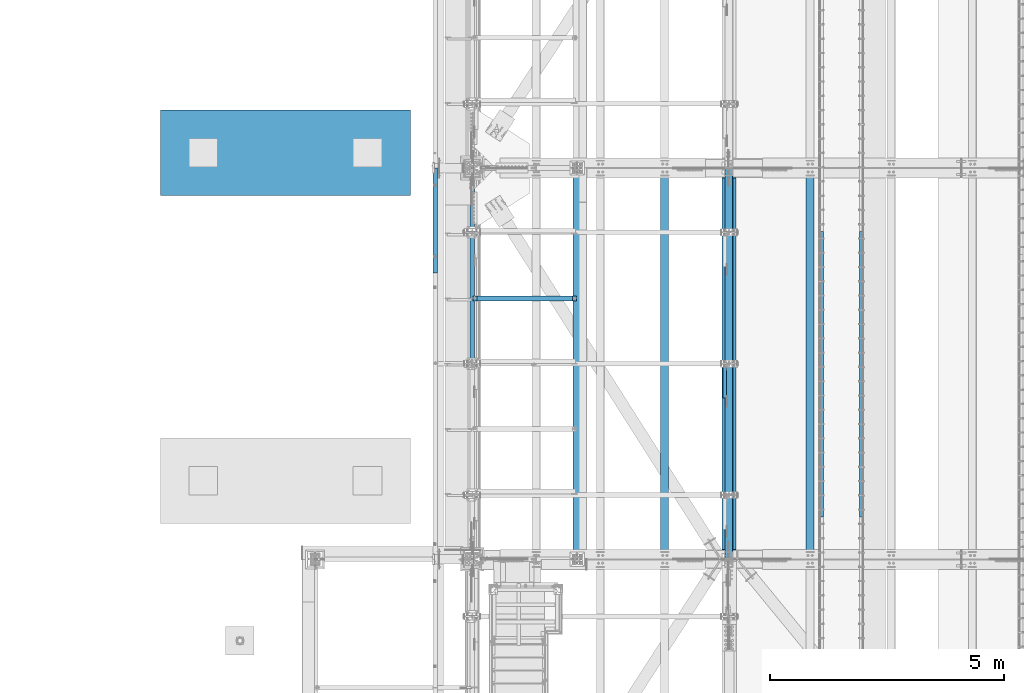
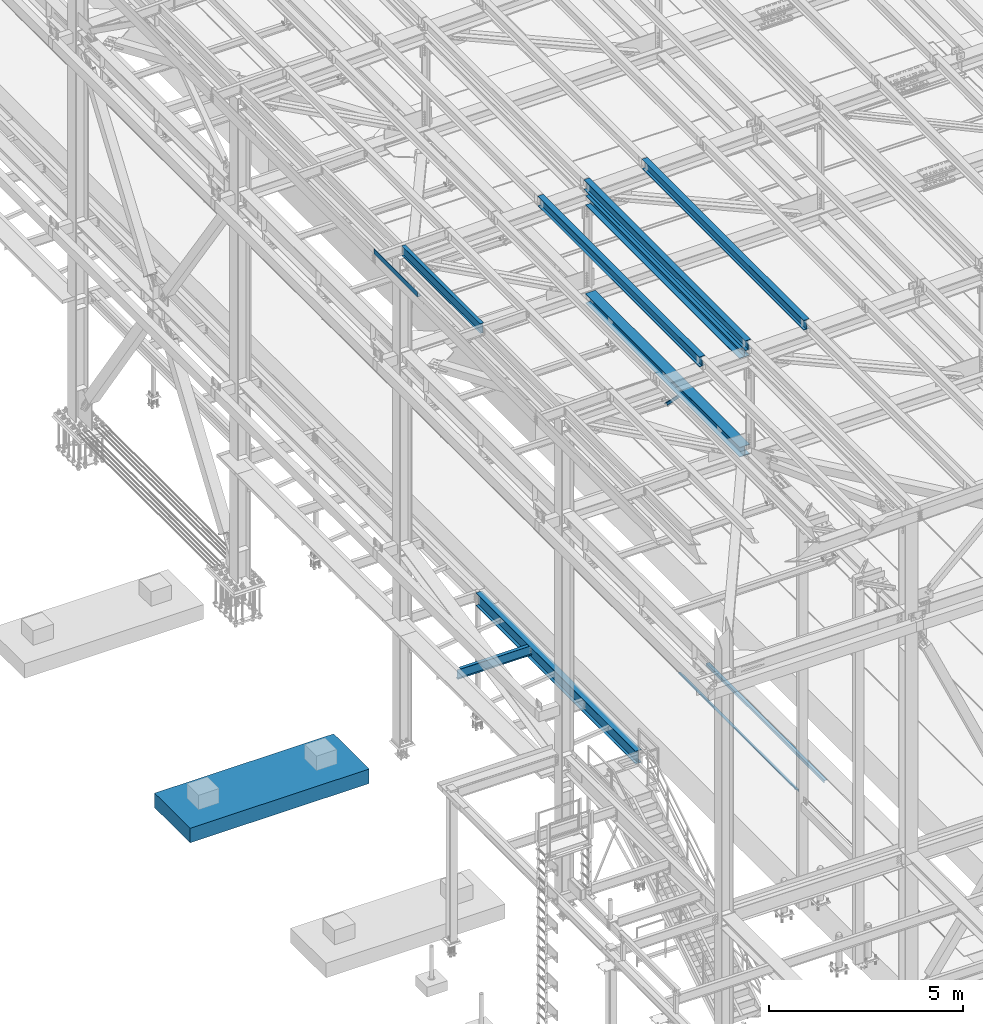
# One storey, part 1807 of 3843: 12 beams, 1 member, 13 elements without a shape of their own.
"""IFC2X3 building model written with IfcOpenShell, lengths in millimetres."""

from ifc_helpers import new_model, si_unit, frame, origin_with_axes, place, context, subcontext, project, spatial, faceted_brep, material, type_object, element, aggregate, save


model = new_model("IFC2X3")

# Units and contexts
model_context = context("Model", 3, precision=1e-05, world=origin_with_axes())
body_context = subcontext(model_context, "Body", "Model", "MODEL_VIEW")
ifc_project = project(units=[si_unit("LENGTHUNIT", "METRE", prefix="MILLI"), si_unit("AREAUNIT", "SQUARE_METRE"), si_unit("VOLUMEUNIT", "CUBIC_METRE"), si_unit("MASSUNIT", "GRAM", prefix="KILO"), si_unit("TIMEUNIT", "SECOND"), si_unit("PLANEANGLEUNIT", "RADIAN"), si_unit("SOLIDANGLEUNIT", "STERADIAN"), si_unit("THERMODYNAMICTEMPERATUREUNIT", "DEGREE_CELSIUS"), si_unit("LUMINOUSINTENSITYUNIT", "LUMEN")], contexts=[model_context])

# Site, building, storey
site_placement = place(None, origin_with_axes())
site = spatial("IfcSite", under=ifc_project, at=site_placement, CompositionType="ELEMENT")
building_placement = place(site_placement, origin_with_axes())
building = spatial("IfcBuilding", under=site, at=building_placement, Name="Undefined", CompositionType="ELEMENT")
storey_placement = place(building_placement, origin_with_axes())
storey = spatial("IfcBuildingStorey", under=building, at=storey_placement, Name="Undefined", CompositionType="ELEMENT", Elevation=0.0)

# Assembly, beam
assembly_1_placement = place(storey_placement, origin_with_axes())
assembly_1 = element("IfcElementAssembly", 1, at=assembly_1_placement, inside=storey, Name="EMBED_ANGLE", AssemblyPlace="NOTDEFINED", PredefinedType="RIGID_FRAME")
ifc_material_1 = material(Name="STEEL/A36")
beam_type_1 = type_object("IfcBeamType", Name="L3-1/2X3-1/2X5/16", PredefinedType="NOTDEFINED")
beam_1_placement = place(assembly_1_placement, frame((44887.896, 40846.375, 30419.675), z_axis=(0.0, 0.0, -1.0), x_axis=(0.0, -1.0, 0.0)))
beam_1 = element("IfcBeam", 2, at=beam_1_placement, type_object=beam_type_1, material=ifc_material_1, Name="EMBED_ANGLE", ObjectType="L3-1/2X3-1/2X5/16", context=body_context, shape_type="Brep", body=[
    faceted_brep([(-3.63797880709171e-12, 44.4499999999971, -44.4500000000007), (-3.63797880709171e-12, 44.4499999999971, 44.4500000000007), (6096.0, 44.4499999999971, 44.4500000000007), (6096.0, 44.4499999999971, -44.4500000000007), (-3.63797880709171e-12, 36.5124999999971, 44.4500000000007), (6096.0, 36.5124999999971, 44.4500000000007), (-3.63797880709171e-12, 36.5124999999971, -36.5125000000007), (6096.0, 36.5124999999971, -36.5125000000007), (3.63797880709171e-12, -44.4499999999971, -36.5125000000007), (6096.0, -44.4499999999971, -36.5125000000007), (3.63797880709171e-12, -44.4499999999971, -44.4500000000007), (6096.0, -44.4499999999971, -44.4500000000007)], [[[0, 1, 2, 3]], [[1, 4, 5, 2]], [[4, 6, 7, 5]], [[6, 8, 9, 7]], [[8, 10, 11, 9]], [[10, 0, 3, 11]], [[5, 7, 9, 11, 3, 2]], [[10, 8, 6, 4, 1, 0]]]),
])
aggregate(assembly_1, [beam_1])

assembly_2_placement = place(storey_placement, origin_with_axes())
assembly_2 = element("IfcElementAssembly", 3, at=assembly_2_placement, inside=storey, Name="EMBED_ANGLE", AssemblyPlace="NOTDEFINED", PredefinedType="RIGID_FRAME")
beam_2_placement = place(assembly_2_placement, frame((44036.996, 34750.375, 30419.675), z_axis=(0.0, 0.0, -1.0), x_axis=(0.0, 1.0, 0.0)))
beam_2 = element("IfcBeam", 4, at=beam_2_placement, type_object=beam_type_1, material=ifc_material_1, Name="EMBED_ANGLE", ObjectType="L3-1/2X3-1/2X5/16", context=body_context, shape_type="Brep", body=[
    faceted_brep([(-3.63797880709171e-12, 44.4499999999971, -44.4500000000007), (-3.63797880709171e-12, 44.4499999999971, 44.4500000000007), (6096.0, 44.4499999999971, 44.4500000000007), (6096.0, 44.4499999999971, -44.4500000000007), (-3.63797880709171e-12, 36.5124999999971, 44.4500000000007), (6096.0, 36.5124999999971, 44.4500000000007), (-3.63797880709171e-12, 36.5124999999971, -36.5125000000007), (6096.0, 36.5124999999971, -36.5125000000007), (3.63797880709171e-12, -44.4499999999971, -36.5125000000007), (6096.0, -44.4499999999971, -36.5125000000007), (3.63797880709171e-12, -44.4499999999971, -44.4500000000007), (6096.0, -44.4499999999971, -44.4500000000007)], [[[0, 1, 2, 3]], [[1, 4, 5, 2]], [[4, 6, 7, 5]], [[6, 8, 9, 7]], [[8, 10, 11, 9]], [[10, 0, 3, 11]], [[5, 7, 9, 11, 3, 2]], [[10, 8, 6, 4, 1, 0]]]),
])
aggregate(assembly_2, [beam_2])

assembly_3_placement = place(storey_placement, origin_with_axes())
assembly_3 = element("IfcElementAssembly", 5, at=assembly_3_placement, inside=storey, Name="BEAM", AssemblyPlace="NOTDEFINED", PredefinedType="RIGID_FRAME")
ifc_material_2 = material(Name="STEEL/A992")
beam_type_2 = type_object("IfcBeamType", Name="W12X26", PredefinedType="NOTDEFINED")
beam_3_placement = place(assembly_3_placement, frame((43792.6592622715, 33844.9442481478, 45730.1489699983), z_axis=(-0.0211520980270507, -0.00357224400155975, 0.999769887435027), x_axis=(0.0, 0.999993616661491, 0.00357304299879051)))
beam_3 = element("IfcBeam", 6, at=beam_3_placement, type_object=beam_type_2, material=ifc_material_2, Name="BEAM", ObjectType="W12X26", context=body_context, shape_type="Brep", body=[
    faceted_brep([(12.6938421735031, 82.5500000000029, -155.574999999895), (12.7278680109448, 82.5499999999956, -146.049999999908), (8343.98104926423, 82.5500000005995, -146.050000028117), (8343.94702342679, 82.5500000005995, -155.575000028111), (12.733867001647, 3.17500000011933, -146.049999999894), (8343.98704825494, 3.17500000071595, -146.050000028103), (13.7773260165704, 3.17499999986467, 146.049999999799), (8345.03050726985, 3.1750000004613, 146.04999997159), (13.771327025861, 82.5499999997337, 146.049999999792), (8345.02450827915, 82.5500000003303, 146.049999971568), (13.8053528633027, 82.5499999997264, 155.574999999786), (8345.05853411659, 82.5500000003231, 155.574999971563), (13.8178307639828, -82.5500000000102, 155.574999999808), (8345.07101201726, -82.5499999994136, 155.574999971599), (13.7838049265338, -82.5499999999956, 146.049999999821), (8345.03698617982, -82.549999999399, 146.049999971612), (13.7778059358243, -3.1750000001266, 146.049999999806), (8345.03098718911, -3.17499999952997, 146.04999997159), (12.7343469209081, -3.17499999987194, -146.049999999894), (8343.98752817419, -3.17499999926804, -146.050000028103), (12.7403459116176, -82.549999999741, -146.049999999872), (8343.9935271649, -82.5499999991443, -146.050000028088), (12.7063200741686, -82.5499999997337, -155.574999999866), (8343.95950132746, -82.5499999991371, -155.575000028075)], [[[0, 1, 2, 3]], [[1, 4, 5, 2]], [[4, 6, 7, 5]], [[6, 8, 9, 7]], [[8, 10, 11, 9]], [[10, 12, 13, 11]], [[12, 14, 15, 13]], [[14, 16, 17, 15]], [[16, 18, 19, 17]], [[18, 20, 21, 19]], [[20, 22, 23, 21]], [[22, 0, 3, 23]], [[5, 7, 9, 11, 13, 15, 17, 19, 21, 23, 3, 2]], [[22, 20, 18, 16, 14, 12, 10, 8, 6, 4, 1, 0]]]),
])
aggregate(assembly_3, [beam_3])

assembly_4_placement = place(storey_placement, origin_with_axes())
assembly_4 = element("IfcElementAssembly", 7, at=assembly_4_placement, inside=storey, Name="BEAM", AssemblyPlace="NOTDEFINED", PredefinedType="RIGID_FRAME")
beam_4_placement = place(assembly_4_placement, frame((42059.109262357, 33845.0630557976, 45692.6365152304), z_axis=(-0.0211520984707749, -0.0028085760011163, 0.999772324397474), x_axis=(0.0, 0.999996054178657, 0.00280920400050223)))
beam_4 = element("IfcBeam", 8, at=beam_4_placement, type_object=beam_type_2, material=ifc_material_2, Name="BEAM", ObjectType="W12X26", context=body_context, shape_type="Brep", body=[
    faceted_brep([(12.6951449950939, 82.5499999999229, -155.574999999968), (12.7218967822482, 82.5499999999156, -146.049999999967), (8343.95477028497, 82.5499999998065, -146.049999994946), (8343.92801849783, 82.549999999821, -155.574999994948), (12.7266133078811, 3.17500000004657, -146.050000000003), (8343.95948681061, 3.1749999999447, -146.049999994975), (13.5470014470411, 3.17499999995925, 146.050000000003), (8344.77987494977, 3.17499999985739, 146.050000005023), (13.5422849214083, 82.5499999998283, 146.050000000039), (8344.77515842414, 82.5499999997264, 146.05000000506), (13.5690367085481, 82.5499999998283, 155.575000000033), (8344.80191021128, 82.5499999997264, 155.575000005054), (13.5788470818734, -82.5499999999156, 155.574999999975), (8344.81172058461, -82.5500000000175, 155.575000004996), (13.5520952947263, -82.549999999901, 146.049999999974), (8344.78496879745, -82.5500000000102, 146.050000004994), (13.5473787690935, -3.17500000003201, 146.050000000003), (8344.78025227182, -3.17500000013388, 146.050000005031), (12.7269906299261, -3.17499999995198, -146.049999999996), (8343.95986413266, -3.17500000005384, -146.049999994975), (12.731707155559, -82.5499999998137, -146.050000000025), (8343.96458065829, -82.5499999999156, -146.049999995004), (12.7049553684119, -82.549999999821, -155.575000000033), (8343.93782887115, -82.5499999999229, -155.574999995006)], [[[0, 1, 2, 3]], [[1, 4, 5, 2]], [[4, 6, 7, 5]], [[6, 8, 9, 7]], [[8, 10, 11, 9]], [[10, 12, 13, 11]], [[12, 14, 15, 13]], [[14, 16, 17, 15]], [[16, 18, 19, 17]], [[18, 20, 21, 19]], [[20, 22, 23, 21]], [[22, 0, 3, 23]], [[5, 7, 9, 11, 13, 15, 17, 19, 21, 23, 3, 2]], [[22, 20, 18, 16, 14, 12, 10, 8, 6, 4, 1, 0]]]),
])
aggregate(assembly_4, [beam_4])

assembly_5_placement = place(storey_placement, origin_with_axes())
assembly_5 = element("IfcElementAssembly", 9, at=assembly_5_placement, inside=storey, Name="BEAM", AssemblyPlace="NOTDEFINED", PredefinedType="RIGID_FRAME")
beam_5_placement = place(assembly_5_placement, frame((40687.5092622838, 33845.1634526064, 45662.9562809056), z_axis=(-0.0211520975230524, -0.00216324900001201, 0.999773929008023), x_axis=(0.0, 0.999997659127012, 0.00216373300027473)))
beam_5 = element("IfcBeam", 10, at=beam_5_placement, type_object=beam_type_2, material=ifc_material_2, Name="BEAM", ObjectType="W12X26", context=body_context, shape_type="Brep", body=[
    faceted_brep([(12.6962491661034, 82.5500000011525, -155.574999999822), (12.7168677113004, 82.5500000010943, -146.049999999806), (8343.93639575265, 82.5500000007887, -146.049999985175), (8343.91577720745, 82.5500000008469, -155.574999985183), (12.7205029037432, 3.1750000006723, -146.05000000009), (8343.94003094509, 3.17500000036671, -146.049999985451), (13.3523758405718, 3.17500000017026, 146.049999999886), (8344.57187818347, 3.17500000035943, 146.049999990741), (13.348743037197, 82.5500000000247, 146.049999999675), (8344.5682453801, 82.5500000002139, 146.049999990537), (13.3693480312504, 82.550000000032, 155.57499999967), (8344.58885037415, 82.5500000002285, 155.574999990531), (13.3769042622662, -82.5499999996682, 155.575000000099), (8344.59640660517, -82.549999999479, 155.57499999096), (13.3562992682055, -82.5499999996828, 146.050000000105), (8344.57580161111, -82.5499999994936, 146.049999990966), (13.352666464838, -3.17499999982101, 146.049999999901), (8344.57216880774, -3.17499999963184, 146.049999990762), (12.7207937191342, -3.17499999936263, -146.050000000105), (8343.94032176048, -3.17499999966822, -146.04999998548), (12.724428911577, -82.5499999997846, -146.050000000381), (8343.94395695291, -82.5500000000902, -146.049999985757), (12.7038103663726, -82.5499999997555, -155.57500000039), (8343.92333840771, -82.5500000000466, -155.574999985758)], [[[0, 1, 2, 3]], [[1, 4, 5, 2]], [[4, 6, 7, 5]], [[6, 8, 9, 7]], [[8, 10, 11, 9]], [[10, 12, 13, 11]], [[12, 14, 15, 13]], [[14, 16, 17, 15]], [[16, 18, 19, 17]], [[18, 20, 21, 19]], [[20, 22, 23, 21]], [[22, 0, 3, 23]], [[5, 7, 9, 11, 13, 15, 17, 19, 21, 23, 3, 2]], [[22, 20, 18, 16, 14, 12, 10, 8, 6, 4, 1, 0]]]),
])
aggregate(assembly_5, [beam_5])

assembly_6_placement = place(storey_placement, origin_with_axes())
assembly_6 = element("IfcElementAssembly", 11, at=assembly_6_placement, inside=storey, Name="BEAM", AssemblyPlace="NOTDEFINED", PredefinedType="RIGID_FRAME")
beam_type_3 = type_object("IfcBeamType", PredefinedType="NOTDEFINED")
beam_6_placement = place(assembly_6_placement, frame((35839.3101109853, 41078.15, 45717.1843160672), z_axis=(0.0, -1.0, 0.0), x_axis=(-0.999776270257024, 0.0, -0.0211520550054595)))
beam_6 = element("IfcBeam", 12, at=beam_6_placement, type_object=beam_type_3, material=ifc_material_1, Name="BENT_PLATE", context=body_context, shape_type="Brep", body=[
    faceted_brep([(-7.27595761418343e-12, -4.77739376947284e-08, 1120.775), (-7.27595761418343e-12, -3.17500000000291, 1117.60000004771), (95.2499999984138, -3.17499999993015, 1117.60000004771), (98.4249999509411, -4.77011781185865e-08, 1120.775), (95.2499999992069, -161.924999997405, 1117.60000004772), (98.4249999517488, -161.924999997391, 1120.775), (95.2499999984138, -3.17499999993015, -1120.775), (95.2499999992069, -161.924999997405, -1120.775), (-7.27595761418343e-12, 3.17499999998836, 1120.775), (-7.27595761418343e-12, 3.17499999998836, -1120.775), (-7.27595761418343e-12, -3.17500000000291, -1120.775), (101.599999998383, 3.17500000006112, 1120.775), (101.599999998383, 3.17500000006112, -1120.775), (101.599999999198, -161.924999997369, 1120.775), (101.599999999198, -161.924999997369, -1120.775)], [[[0, 1, 2, 3]], [[3, 2, 4, 5]], [[6, 7, 4, 2]], [[8, 9, 10, 1, 0]], [[9, 8, 11, 12]], [[10, 6, 2, 1]], [[12, 11, 13, 14]], [[13, 11, 8, 0, 3, 5]], [[6, 10, 9, 12, 14, 7]], [[7, 14, 13, 5, 4]]]),
])
aggregate(assembly_6, [beam_6])

assembly_7_placement = place(storey_placement, origin_with_axes())
assembly_7 = element("IfcElementAssembly", 13, at=assembly_7_placement, inside=storey, Name="BEAM", AssemblyPlace="NOTDEFINED", PredefinedType="RIGID_FRAME")
beam_type_4 = type_object("IfcBeamType", Name="W12X19", PredefinedType="NOTDEFINED")
beam_7_placement = place(assembly_7_placement, frame((36575.9999999303, 38023.8, 45575.6071293686), z_axis=(0.0, 0.0, 1.0), x_axis=(0.0, 1.0, 0.0)))
beam_7 = element("IfcBeam", 14, at=beam_7_placement, type_object=beam_type_4, material=ifc_material_2, Name="BEAM", ObjectType="W12X19", context=body_context, shape_type="Brep", body=[
    faceted_brep([(4111.62499999991, -3.17500000000291, -144.462500000001), (4111.62499999991, -50.8000000000029, -144.462500000001), (4111.62499999991, -50.8000000000029, -153.987500000003), (4111.62499999991, 50.8000000000029, -153.987500000003), (4111.62499999991, 50.8000000000029, -144.462500000001), (4111.62499999991, 3.17500000000291, -144.462500000001), (4111.62499999991, 3.17500000000291, -141.287499808204), (4111.62499999991, -3.17500000000291, -141.287499808204), (4112.5917299225, 3.17500000000291, -136.427420290158), (4112.5917299225, -3.17500000000291, -136.427420290158), (4115.34474382298, 3.17500000000291, -132.307243822004), (4115.34474382298, -3.17500000000291, -132.307243822004), (4119.46492029114, 3.17500000000291, -129.55422992153), (4119.46492029114, -3.17500000000291, -129.55422992153), (4124.32499980918, 3.17500000000291, -128.587499998939), (4124.32499980918, -3.17500000000291, -128.587499998939), (4162.42499999992, -3.17500000000291, -128.587499998939), (4162.42499999992, 3.17500000000291, -128.587499998939), (4111.62499999991, 50.8000000000029, 144.462500000001), (4111.62499999991, 3.17500000000291, 144.462500000001), (66.6750000000175, 3.17500000000291, 144.462500000001), (66.6750000000175, 50.8000000000029, 144.462500000001), (66.6750000000175, -3.17500000000291, -141.287499808226), (66.6750000000175, 3.17500000000291, -141.287499808226), (66.6750000000175, 3.17500000000291, -144.462500000001), (66.6750000000175, 50.8000000000029, -144.462500000001), (66.6750000000175, 50.8000000000029, -153.987500000003), (66.6750000000175, -50.8000000000029, -153.987500000003), (66.6750000000175, -50.8000000000029, -144.462500000001), (66.6750000000175, -3.17500000000291, -144.462500000001), (65.7082700774336, -3.17500000000291, -136.42742029018), (65.7082700774336, 3.17500000000291, -136.42742029018), (62.9552561769524, -3.17500000000291, -132.307243822026), (62.9552561769524, 3.17500000000291, -132.307243822026), (58.8350797087915, -3.17500000000291, -129.554229921552), (58.8350797087915, 3.17500000000291, -129.554229921552), (53.9750001907523, -3.17500000000291, -128.587499998961), (53.9750001907523, 3.17500000000291, -128.587499998961), (15.8750000000146, -3.17500000000291, -128.587499998961), (15.8750000000146, 3.17500000000291, -128.587499998961), (15.8750000000146, -3.17500000000291, 128.587500001042), (15.8750000000146, 3.17500000000291, 128.587500001042), (15.8750000000146, 3.17500000000291, 115.887500001612), (15.8750000000146, 3.17500000000291, -114.712499998386), (53.9750001907523, -3.17500000000291, 128.587500001042), (53.9750001907523, 3.17500000000291, 128.587500001042), (58.8350797087915, -3.17500000000291, 129.554229923633), (58.8350797087915, 3.17500000000291, 129.554229923633), (62.9552561769524, -3.17500000000291, 132.307243824107), (62.9552561769524, 3.17500000000291, 132.307243824107), (65.7082700774336, -3.17500000000291, 136.427420292261), (65.7082700774336, 3.17500000000291, 136.427420292261), (66.6750000000175, -3.17500000000291, 141.287499810307), (66.6750000000175, 3.17500000000291, 141.287499810307), (66.6750000000175, -50.8000000000029, 153.987500000003), (66.6750000000175, 50.8000000000029, 153.987500000003), (66.6750000000175, -3.17500000000291, 144.462500000001), (66.6750000000175, -50.8000000000029, 144.462500000001), (4111.62499999991, -3.17500000000291, 144.462500000001), (4111.62499999991, -50.8000000000029, 144.462500000001), (4111.62499999991, -50.8000000000029, 153.987500000003), (4111.62499999991, 50.8000000000029, 153.987500000003), (4111.62499999991, -3.17500000000291, 141.287499810329), (4111.62499999991, 3.17500000000291, 141.287499810329), (4112.5917299225, -3.17500000000291, 136.427420292282), (4112.5917299225, 3.17500000000291, 136.427420292282), (4115.34474382298, -3.17500000000291, 132.307243824129), (4115.34474382298, 3.17500000000291, 132.307243824129), (4119.46492029114, -3.17500000000291, 129.554229923655), (4119.46492029114, 3.17500000000291, 129.554229923655), (4124.32499980918, -3.17500000000291, 128.587500001064), (4124.32499980918, 3.17500000000291, 128.587500001064), (4162.42499999992, -3.17500000000291, 128.587500001064), (4162.42499999992, 3.17500000000291, 128.587500001064), (4162.42499999992, 3.17500000000291, -114.712499998423), (4162.42499999992, 3.17500000000291, 115.887500001576)], [[[0, 1, 2, 3, 4, 5, 6, 7]], [[7, 6, 8, 9]], [[9, 8, 10, 11]], [[11, 10, 12, 13]], [[13, 12, 14, 15]], [[16, 15, 14, 17]], [[18, 19, 20, 21]], [[22, 23, 24, 25, 26, 27, 28, 29]], [[30, 31, 23, 22]], [[32, 33, 31, 30]], [[34, 35, 33, 32]], [[36, 37, 35, 34]], [[38, 39, 37, 36]], [[40, 41, 42, 43, 39, 38]], [[44, 45, 41, 40]], [[46, 47, 45, 44]], [[48, 49, 47, 46]], [[50, 51, 49, 48]], [[52, 53, 51, 50]], [[54, 55, 21, 20, 53, 52, 56, 57]], [[58, 59, 57, 56]], [[59, 60, 54, 57]], [[60, 61, 55, 54]], [[61, 18, 21, 55]], [[60, 59, 58, 62, 63, 19, 18, 61]], [[64, 65, 63, 62]], [[66, 67, 65, 64]], [[68, 69, 67, 66]], [[70, 71, 69, 68]], [[72, 73, 71, 70]], [[74, 75, 73, 72, 16, 17]], [[33, 35, 37, 39, 43, 42, 41, 45, 47, 49, 51, 53, 20, 19, 63, 65, 67, 69, 71, 73, 75, 74, 17, 14, 12, 10, 8, 6, 5, 24, 23, 31]], [[5, 4, 25, 24]], [[4, 3, 26, 25]], [[3, 2, 27, 26]], [[2, 1, 28, 27]], [[1, 0, 29, 28]], [[0, 7, 9, 11, 13, 15, 16, 72, 70, 68, 66, 64, 62, 58, 56, 52, 50, 48, 46, 44, 40, 38, 36, 34, 32, 30, 22, 29]]]),
])
aggregate(assembly_7, [beam_7])

# Assembly, member
assembly_8_placement = place(storey_placement, origin_with_axes())
assembly_8 = element("IfcElementAssembly", 15, at=assembly_8_placement, inside=storey, Name="ANGLE", AssemblyPlace="NOTDEFINED", PredefinedType="RIGID_FRAME")
ifc_material_3 = material(Name="STEEL/A572-50")
member_type = type_object("IfcMemberType", Name="L3X3X1/4", PredefinedType="NOTDEFINED")
member_placement = place(assembly_8_placement, frame((41973.5, 37061.6602212791, 42262.5397787209), z_axis=(0.0, -0.707106781186548, -0.707106781186548), x_axis=(5.70000238222118e-08, 0.707106781186546, -0.707106781186546)))
member = element("IfcMember", 16, at=member_placement, type_object=member_type, material=ifc_material_3, Name="ANGLE", ObjectType="L3X3X1/4", context=body_context, shape_type="Brep", body=[
    faceted_brep([(1277.66984329856, -38.0999999999985, -31.74999999992), (1277.66984329856, -38.0999999999985, -38.099999999904), (1277.66984329856, 38.0999999999985, -38.099999999904), (1277.66984329856, 38.0999999999985, 38.0999999999112), (1277.66984329856, 31.75, 38.0999999999112), (1277.66984329856, 31.75, -31.74999999992), (287.069843298529, 31.75, 38.0999999999112), (287.069843298533, 31.75, -31.74999999992), (287.069843298533, -38.0999999999985, -31.74999999992), (287.069843298533, -38.0999999999985, -38.099999999904), (287.069843298533, 38.0999999999985, -38.099999999904), (287.069843298529, 38.0999999999985, 38.0999999999112)], [[[0, 1, 2, 3, 4, 5]], [[5, 4, 6, 7]], [[0, 5, 7, 8]], [[1, 0, 8, 9]], [[2, 1, 9, 10]], [[3, 2, 10, 11]], [[4, 3, 11, 6]], [[10, 9, 8, 7, 6, 11]]]),
])
aggregate(assembly_8, [member])

# Assembly, beam
assembly_9_placement = place(storey_placement, origin_with_axes())
assembly_9 = element("IfcElementAssembly", 17, at=assembly_9_placement, inside=storey, Name="BEAM", AssemblyPlace="NOTDEFINED", PredefinedType="RIGID_FRAME")
beam_type_5 = type_object("IfcBeamType", Name="W12X65", PredefinedType="NOTDEFINED")
beam_8_placement = place(assembly_9_placement, frame((42062.4, 33845.5, 42249.1989165259), z_axis=(0.0, -0.00280793599926983, 0.999996057739941), x_axis=(0.0, 0.999996057739941, 0.00280793599926953)))
beam_8 = element("IfcBeam", 18, at=beam_8_placement, type_object=beam_type_5, material=ifc_material_2, Name="BEAM", ObjectType="W12X65", context=body_context, shape_type="Brep", body=[
    faceted_brep([(198.005893546338, 152.400000000001, -153.98750000033), (198.050469706053, 152.400000000001, -138.112500000323), (8157.80684914687, 152.400000000001, -138.112500009374), (8157.76227298714, 152.400000000001, -153.987500009382), (198.050469706053, 4.76249999999709, -138.112500000323), (8157.80684914687, 4.76249999999709, -138.112500009374), (198.826094885175, 4.76249999999709, 138.112499999872), (8158.58247432598, 4.76249999999709, 138.112499990821), (198.826094885175, 152.400000000001, 138.112499999872), (8158.58247432598, 152.400000000001, 138.112499990821), (198.87067104489, 152.400000000001, 153.987499999886), (8158.62705048569, 152.400000000001, 153.987499990835), (198.87067104489, -152.400000000001, 153.987499999886), (8158.62705048569, -152.400000000001, 153.987499990835), (198.826094885175, -152.400000000001, 138.112499999872), (8158.58247432598, -152.400000000001, 138.112499990821), (198.826094885175, -4.76249999999709, 138.112499999872), (8158.58247432598, -4.76249999999709, 138.112499990821), (198.050469706053, -4.76249999999709, -138.112500000323), (8157.80684914687, -4.76249999999709, -138.112500009374), (198.050469706053, -152.400000000001, -138.112500000323), (8157.80684914687, -152.400000000001, -138.112500009374), (198.005893546338, -152.400000000001, -153.98750000033), (8157.76227298714, -152.400000000001, -153.987500009382)], [[[0, 1, 2, 3]], [[1, 4, 5, 2]], [[4, 6, 7, 5]], [[6, 8, 9, 7]], [[8, 10, 11, 9]], [[10, 12, 13, 11]], [[12, 14, 15, 13]], [[14, 16, 17, 15]], [[16, 18, 19, 17]], [[18, 20, 21, 19]], [[20, 22, 23, 21]], [[22, 0, 3, 23]], [[5, 7, 9, 11, 13, 15, 17, 19, 21, 23, 3, 2]], [[22, 20, 18, 16, 14, 12, 10, 8, 6, 4, 1, 0]]]),
])
aggregate(assembly_9, [beam_8])

assembly_10_placement = place(storey_placement, origin_with_axes())
assembly_10 = element("IfcElementAssembly", 19, at=assembly_10_placement, inside=storey, Name="BEAM", AssemblyPlace="NOTDEFINED", PredefinedType="RIGID_FRAME")
beam_9_placement = place(assembly_10_placement, frame((42062.4, 33845.5, 45340.2008527698), z_axis=(0.0, -0.00280920400049945, 0.999996054178657), x_axis=(0.0, 0.999996054178657, 0.00280920400050223)))
beam_9 = element("IfcBeam", 20, at=beam_9_placement, type_object=beam_type_5, material=ifc_material_2, Name="BEAM", ObjectType="W12X65", context=body_context, shape_type="Brep", body=[
    faceted_brep([(212.293255368852, 152.400000000001, -153.987499999384), (212.337851658325, 152.400000000001, -138.112499999435), (8143.51914663157, 152.400000000001, -138.112499994648), (8143.47455034209, 152.400000000001, -153.987499994597), (212.337851658325, 4.76249999999709, -138.112499999435), (8143.51914663157, 4.76249999999709, -138.112499994648), (213.113827095221, 4.76249999999709, 138.112499999675), (8144.29512206846, 4.76249999999709, 138.112500004463), (213.113827095221, 152.400000000001, 138.112499999675), (8144.29512206846, 152.400000000001, 138.112500004463), (213.158423384702, 152.400000000001, 153.987499999625), (8144.33971835794, 152.400000000001, 153.987500004412), (213.158423384702, -152.400000000001, 153.987499999625), (8144.33971835794, -152.400000000001, 153.987500004412), (213.113827095221, -152.400000000001, 138.112499999675), (8144.29512206846, -152.400000000001, 138.112500004463), (213.113827095221, -4.76249999999709, 138.112499999675), (8144.29512206846, -4.76249999999709, 138.112500004463), (212.337851658325, -4.76249999999709, -138.112499999435), (8143.51914663157, -4.76249999999709, -138.112499994648), (212.337851658325, -152.400000000001, -138.112499999435), (8143.51914663157, -152.400000000001, -138.112499994648), (212.293255368852, -152.400000000001, -153.987499999384), (8143.47455034209, -152.400000000001, -153.987499994597)], [[[0, 1, 2, 3]], [[1, 4, 5, 2]], [[4, 6, 7, 5]], [[6, 8, 9, 7]], [[8, 10, 11, 9]], [[10, 12, 13, 11]], [[12, 14, 15, 13]], [[14, 16, 17, 15]], [[16, 18, 19, 17]], [[18, 20, 21, 19]], [[20, 22, 23, 21]], [[22, 0, 3, 23]], [[5, 7, 9, 11, 13, 15, 17, 19, 21, 23, 3, 2]], [[22, 20, 18, 16, 14, 12, 10, 8, 6, 4, 1, 0]]]),
])
aggregate(assembly_10, [beam_9])

assembly_11_placement = place(storey_placement, origin_with_axes())
assembly_11 = element("IfcElementAssembly", 21, at=assembly_11_placement, inside=storey, Name="BEAM", AssemblyPlace="NOTDEFINED", PredefinedType="RIGID_FRAME")
beam_type_6 = type_object("IfcBeamType", Name="W16X40", PredefinedType="NOTDEFINED")
beam_10_placement = place(assembly_11_placement, frame((38820.725, 33845.5, 33832.8), z_axis=(0.0, 0.0, 1.0), x_axis=(0.0, 1.0, 0.0)))
beam_10 = element("IfcBeam", 22, at=beam_10_placement, type_object=beam_type_6, material=ifc_material_2, Name="BEAM", ObjectType="W16X40", context=body_context, shape_type="Brep", body=[
    faceted_brep([(63.4999999999854, -88.9000000000015, -203.199999999997), (63.4999999999854, 88.9000000000015, -203.199999999997), (8293.09999999999, 88.9000000000015, -203.199999999997), (8293.09999999999, -88.9000000000015, -203.199999999997), (63.4999999999854, -88.9000000000015, -190.5), (63.4999999999854, -3.96875, -190.5), (63.4999999999854, -3.96875, 190.5), (63.4999999999854, -88.9000000000015, 190.5), (63.4999999999854, -88.9000000000015, 203.199999999997), (63.4999999999854, 88.9000000000015, 203.199999999997), (63.4999999999854, 88.9000000000015, 190.5), (63.4999999999854, 3.96875, 190.5), (63.4999999999854, 3.96875, -190.5), (63.4999999999854, 88.9000000000015, -190.5), (8293.09999999999, -88.9000000000015, -190.5), (8293.09999999999, -3.96875, -190.5), (8293.09999999999, -3.96875, 190.5), (8293.09999999999, -88.9000000000015, 190.5), (8293.09999999999, -88.9000000000015, 203.199999999997), (8293.09999999999, 88.9000000000015, 203.199999999997), (8293.09999999999, 88.9000000000015, 190.5), (8293.09999999999, 3.96875, 190.5), (8293.09999999999, 3.96875, -190.5), (8293.09999999999, 88.9000000000015, -190.5)], [[[0, 1, 2, 3]], [[0, 4, 5, 6, 7, 8, 9, 10, 11, 12, 13, 1]], [[5, 4, 14, 15]], [[6, 5, 15, 16]], [[7, 6, 16, 17]], [[8, 7, 17, 18]], [[9, 8, 18, 19]], [[10, 9, 19, 20]], [[11, 10, 20, 21]], [[12, 11, 21, 22]], [[13, 12, 22, 23]], [[1, 13, 23, 2]], [[22, 21, 20, 19, 18, 17, 16, 15, 14, 3, 2, 23]], [[4, 0, 3, 14]]]),
])
aggregate(assembly_11, [beam_10])

assembly_12_placement = place(storey_placement, origin_with_axes())
assembly_12 = element("IfcElementAssembly", 23, at=assembly_12_placement, inside=storey, Name="BEAM", AssemblyPlace="NOTDEFINED", PredefinedType="RIGID_FRAME")
beam_type_7 = type_object("IfcBeamType", Name="W12X14", PredefinedType="NOTDEFINED")
beam_11_placement = place(assembly_12_placement, frame((36576.0, 39416.632812, 33885.1875), z_axis=(0.0, 0.0, 1.0), x_axis=(1.0, 0.0, 0.0)))
beam_11 = element("IfcBeam", 24, at=beam_11_placement, type_object=beam_type_7, material=ifc_material_2, Name="BEAM", ObjectType="W12X14", context=body_context, shape_type="Brep", body=[
    faceted_brep([(92.8687501907334, -2.38125000000582, 125.412499999991), (92.8687501907334, 2.38125000000582, 125.412499999991), (16.6687499999971, 2.38125000000582, 125.412499999991), (16.6687499999971, -2.38125000000582, 125.412499999991), (97.7288297087798, -2.38125000000582, 126.379229922582), (97.7288297087798, 2.38125000000582, 126.379229922582), (101.849006176933, -2.38125000000582, 129.132243823056), (101.849006176933, 2.38125000000582, 129.132243823056), (104.602020077407, -2.38125000000582, 133.25242029121), (104.602020077407, 2.38125000000582, 133.25242029121), (105.568749999999, -2.38125000000582, 138.112499809256), (105.568749999999, 2.38125000000582, 138.112499809256), (105.568749999999, -50.8000000000029, 150.812499810811), (105.568749999999, 50.8000000000029, 150.8125), (105.568749999999, 50.8000000000029, 144.462500000001), (105.568749999999, 2.38125000000582, 144.462500000001), (105.568749999999, -2.38125000000582, 144.462500000001), (105.568749999999, -50.8000000000029, 144.462500000001), (16.6687499999971, -2.38125000000582, -144.462500000001), (16.6687499999971, -50.7999999999993, -144.462500000001), (2228.05625, -50.8000000000029, -144.462500000001), (2228.05625, -2.38125000000582, -144.462500000001), (16.6687499999971, -50.8000000000029, -150.8125), (2228.05625, -50.8000000000029, -150.8125), (16.6687499999971, 50.8000000000029, -150.8125), (2228.05625, 50.8000000000029, -150.8125), (16.6687499999971, 50.7999999999993, -144.462500000001), (2228.05625, 50.8000000000029, -144.462500000001), (16.6687499999971, 2.38125000000582, -144.462500000001), (2228.05625, 2.38125000000582, -144.462500000001), (2228.05625, 2.38125000000582, -117.887499999997), (2228.05625, 2.38125000000582, 112.712500000001), (2228.05625, 2.38125000000582, 125.412499999991), (2228.05625, -2.38125000000582, 125.412499999991), (2151.85624980927, 2.38125000000582, 125.412499999991), (2151.85624980927, -2.38125000000582, 125.412499999991), (2146.99617029122, 2.38125000000582, 126.379229922582), (2146.99617029122, -2.38125000000582, 126.379229922582), (2142.87599382307, 2.38125000000582, 129.132243823056), (2142.87599382307, -2.38125000000582, 129.132243823056), (2140.12297992259, 2.38125000000582, 133.25242029121), (2140.12297992259, -2.38125000000582, 133.25242029121), (2139.15625, 2.38125000000582, 138.112499809256), (2139.15625, -2.38125000000582, 138.112499809256), (2139.15625, -50.8000000000029, 150.8125), (2139.15625, -50.8000000000029, 144.462500000001), (2139.15625, -2.38125000000582, 144.462500000001), (2139.15625, 2.38125000000582, 144.462500000001), (2139.15625, 50.8000000000029, 144.462500000001), (2139.15625, 50.8000000000029, 150.8125), (16.6687499999971, 2.38125000000582, 112.712500000001), (16.6687499999971, 2.38125000000582, -117.887499999997)], [[[0, 1, 2, 3]], [[4, 5, 1, 0]], [[6, 7, 5, 4]], [[8, 9, 7, 6]], [[10, 11, 9, 8]], [[12, 13, 14, 15, 11, 10, 16, 17]], [[18, 19, 20, 21]], [[19, 22, 23, 20]], [[22, 24, 25, 23]], [[24, 26, 27, 25]], [[26, 28, 29, 27]], [[21, 20, 23, 25, 27, 29, 30, 31, 32, 33]], [[33, 32, 34, 35]], [[35, 34, 36, 37]], [[37, 36, 38, 39]], [[39, 38, 40, 41]], [[41, 40, 42, 43]], [[44, 45, 46, 43, 42, 47, 48, 49]], [[45, 44, 12, 17]], [[46, 45, 17, 16]], [[8, 6, 4, 0, 3, 18, 21, 33, 35, 37, 39, 41, 43, 46, 16, 10]], [[50, 51, 28, 26, 24, 22, 19, 18, 3, 2]], [[47, 42, 40, 38, 36, 34, 32, 31, 30, 29, 28, 51, 50, 2, 1, 5, 7, 9, 11, 15]], [[48, 47, 15, 14]], [[49, 48, 14, 13]], [[44, 49, 13, 12]]]),
])
aggregate(assembly_12, [beam_11])

assembly_13_placement = place(storey_placement, origin_with_axes())
assembly_13 = element("IfcElementAssembly", 25, at=assembly_13_placement, inside=storey, Name="BEAM", AssemblyPlace="NOTDEFINED", PredefinedType="REINFORCEMENT_UNIT")
ifc_material_4 = material(Name="CONCRETE/5000")
beam_type_8 = type_object("IfcBeamType", PredefinedType="NOTDEFINED")
beam_12_placement = place(assembly_13_placement, frame((29921.2, 42532.3, 29794.2), z_axis=(0.0, 0.0, 1.0), x_axis=(1.0, 0.0, 0.0)))
beam_12 = element("IfcBeam", 26, at=beam_12_placement, type_object=beam_type_8, material=ifc_material_4, Name="BEAM", context=body_context, shape_type="Brep", body=[
    faceted_brep([(0.0, 914.400000000001, -228.599999999999), (0.0, 914.400000000001, 228.599999999999), (5334.0, 914.400000000001, 228.599999999999), (5334.0, 914.400000000001, -228.599999999999), (0.0, -914.400000000001, 228.599999999999), (5334.0, -914.400000000001, 228.599999999999), (0.0, -914.400000000001, -228.599999999999), (5334.0, -914.400000000001, -228.599999999999)], [[[0, 1, 2, 3]], [[1, 4, 5, 2]], [[4, 6, 7, 5]], [[6, 0, 3, 7]], [[5, 7, 3, 2]], [[6, 4, 1, 0]]]),
])
aggregate(assembly_13, [beam_12])

save(model, "model.ifc")
